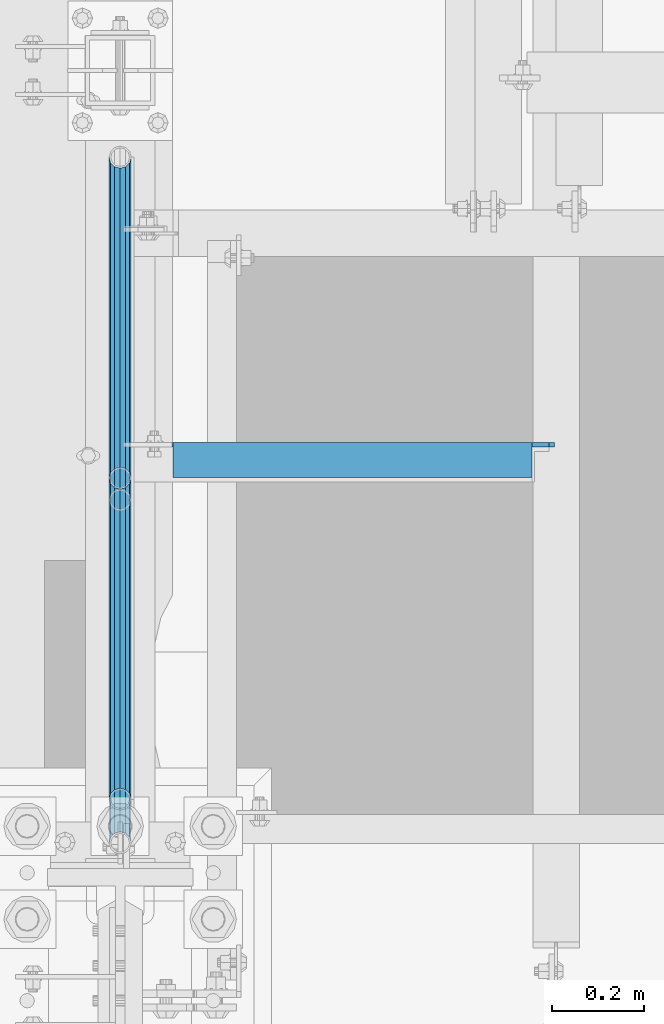
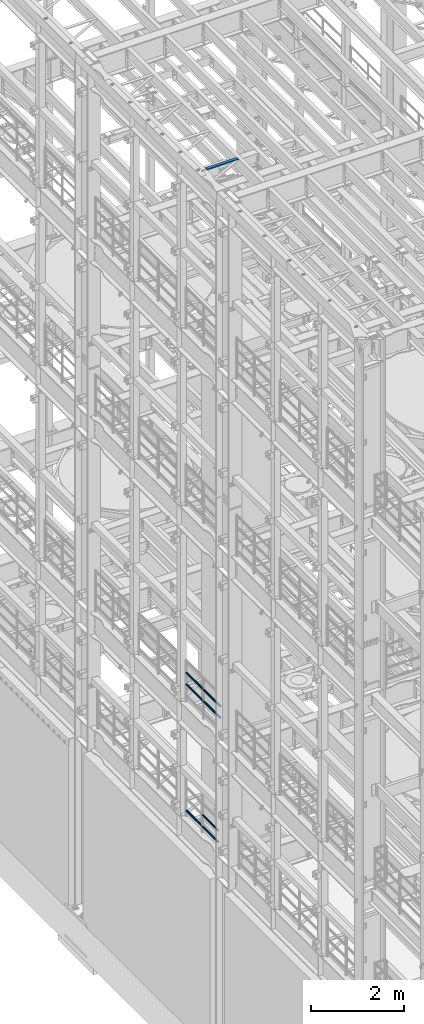
# One storey, part 1246 of 1876: 8 beams, 3 elements without a shape of their own.
"""IFC2X3 building model written with IfcOpenShell, lengths in millimetres."""

from ifc_helpers import new_model, si_unit, frame, origin_with_axes, place, context, subcontext, project, spatial, faceted_brep, material, type_object, element, aggregate, save


model = new_model("IFC2X3")

# Units and contexts
model_context = context("Model", 3, precision=1e-05, world=origin_with_axes())
body_context = subcontext(model_context, "Body", "Model", "MODEL_VIEW")
ifc_project = project(units=[si_unit("LENGTHUNIT", "METRE", prefix="MILLI"), si_unit("AREAUNIT", "SQUARE_METRE"), si_unit("VOLUMEUNIT", "CUBIC_METRE"), si_unit("MASSUNIT", "GRAM", prefix="KILO"), si_unit("TIMEUNIT", "SECOND"), si_unit("PLANEANGLEUNIT", "RADIAN"), si_unit("SOLIDANGLEUNIT", "STERADIAN"), si_unit("THERMODYNAMICTEMPERATUREUNIT", "DEGREE_CELSIUS"), si_unit("LUMINOUSINTENSITYUNIT", "LUMEN")], contexts=[model_context])

# Site, building, storey
site_placement = place(None, origin_with_axes())
site = spatial("IfcSite", under=ifc_project, at=site_placement, CompositionType="ELEMENT")
building_placement = place(site_placement, origin_with_axes())
building = spatial("IfcBuilding", under=site, at=building_placement, Name="Undefined", CompositionType="ELEMENT")
storey_placement = place(building_placement, origin_with_axes())
storey = spatial("IfcBuildingStorey", under=building, at=storey_placement, Name="Undefined", CompositionType="ELEMENT", Elevation=0.0)

# Assembly, beams
assembly_1_placement = place(storey_placement, origin_with_axes())
assembly_1 = element("IfcElementAssembly", 1, at=assembly_1_placement, inside=storey, Name="RAIL", AssemblyPlace="NOTDEFINED", PredefinedType="RIGID_FRAME")
ifc_material_1 = material()
beam_type_1 = type_object("IfcBeamType", Name="PIPE1-1/2SCH40", PredefinedType="NOTDEFINED")
beam_1_placement = place(assembly_1_placement, frame((-1.81898940354586e-12, 1868.805, 8620.125), z_axis=(0.0, 0.0, -1.0), x_axis=(0.0, 1.0, 0.0)))
beam_1 = element("IfcBeam", 2, at=beam_1_placement, type_object=beam_type_1, material=ifc_material_1, Name="RAIL", ObjectType="PIPE1-1/2SCH40", context=body_context, shape_type="Brep", body=[
    faceted_brep([(0.0, 24.1299999999992, 0.0), (12.0650000000064, 20.8971929933177, -12.0649999999987), (12.0650000000064, 20.8971929933177, 12.0649999999987), (12.0650000000064, -20.8971929933177, 12.0649999999987), (12.0650000000064, -20.8971929933177, -12.0649999999987), (0.0, -24.1299999999992, 0.0), (20.8971929933249, -12.0650000000005, 20.8971929933177), (20.8971929933249, -12.0650000000005, 15.8661214311796), (15.2545715621445, -17.7076214311801, 10.2235000000001), (12.5151929933249, -20.4470000000001, 0.0), (15.2545715621445, -17.7076214311801, -10.2235000000001), (20.8971929933249, -12.0650000000005, -15.8661214311796), (20.8971929933249, -12.0650000000005, -20.8971929933177), (24.1300000000063, 0.0, -20.4470000000001), (24.1300000000063, 0.0, -24.130000000001), (21.3906214311868, -10.2235000000001, -17.7076214311819), (21.3906214311868, 10.2235000000001, -17.7076214311819), (20.8971929933249, 12.0650000000005, -15.8661214311796), (20.8971929933249, 12.0650000000005, -20.8971929933177), (15.2545715621445, 17.7076214311801, -10.2235000000001), (12.5151929933249, 20.4470000000001, 0.0), (15.2545715621445, 17.7076214311801, 10.2235000000001), (20.8971929933249, 12.0650000000005, 15.8661214311796), (20.8971929933249, 12.0650000000005, 20.8971929933177), (21.3906214311868, 10.2235000000001, 17.7076214311819), (24.1300000000064, 0.0, 20.4470000000001), (24.1300000000064, 0.0, 24.130000000001), (21.3906214311868, -10.2235000000001, 17.7076214311819), (748.982500000002, 24.1300000000001, 0.0), (736.917500000002, 20.8971929933186, -12.0649999999987), (728.085307006683, 12.0649999999996, -20.8971929933177), (748.982500000002, -24.1300000000001, 0.0), (736.917500000002, -20.8971929933186, -12.0649999999987), (736.917500000002, -20.8971929933186, 12.0649999999987), (728.085307006683, -12.0649999999996, 20.8971929933177), (728.085307006683, -12.0649999999996, -20.8971929933177), (724.852500000002, 0.0, -24.130000000001), (727.591878568821, 10.2235000000001, -17.7076214311819), (724.852500000002, 0.0, -20.4470000000001), (728.085307006683, 12.0649999999996, -15.8661214311796), (728.085307006683, -12.0649999999996, -15.8661214311796), (727.591878568821, -10.2235000000001, -17.7076214311819), (733.727928437864, -17.7076214311801, -10.2235000000001), (736.467307006683, -20.4470000000001, 0.0), (733.727928437864, -17.7076214311801, 10.2235000000001), (728.085307006683, -12.0649999999996, 15.8661214311796), (727.591878568821, -10.2235000000001, 17.7076214311819), (724.852500000002, 0.0, 20.4470000000001), (724.852500000002, 0.0, 24.130000000001), (728.085307006683, 12.0649999999996, 20.8971929933177), (736.917500000002, 20.8971929933186, 12.0649999999987), (728.085307006683, 12.0649999999996, 15.8661214311796), (733.727928437864, 17.7076214311801, 10.2235000000001), (736.467307006683, 20.4470000000001, 0.0), (733.727928437864, 17.7076214311801, -10.2235000000001), (727.591878568821, 10.2235000000001, 17.7076214311819)], [[[0, 1, 2]], [[3, 4, 5]], [[6, 7, 8, 9, 10, 11, 12, 4, 3]], [[13, 14, 12, 11, 15]], [[16, 17, 18, 14, 13]], [[2, 1, 18, 17, 19, 20, 21, 22, 23]], [[23, 22, 24, 25, 26]], [[26, 25, 27, 7, 6]], [[1, 0, 28, 29]], [[18, 1, 29, 30]], [[31, 32, 33]], [[6, 3, 33, 34]], [[3, 5, 31, 33]], [[5, 4, 32, 31]], [[4, 12, 35, 32]], [[12, 14, 36, 35]], [[14, 18, 30, 36]], [[37, 38, 36, 30, 39]], [[40, 35, 36, 38, 41]], [[33, 32, 35, 40, 42, 43, 44, 45, 34]], [[34, 45, 46, 47, 48]], [[26, 6, 34, 48]], [[2, 23, 49, 50]], [[23, 26, 48, 49]], [[0, 2, 50, 28]], [[28, 50, 29]], [[49, 51, 52, 53, 54, 39, 30, 29, 50]], [[48, 47, 55, 51, 49]], [[25, 24, 55, 47]], [[55, 24, 22, 21, 52, 51]], [[21, 20, 53, 52]], [[20, 19, 54, 53]], [[19, 17, 16, 37, 39, 54]], [[16, 13, 38, 37]], [[13, 15, 41, 38]], [[41, 15, 11, 10, 42, 40]], [[10, 9, 43, 42]], [[9, 8, 44, 43]], [[8, 7, 27, 46, 45, 44]], [[27, 25, 47, 46]]]),
])
beam_2_placement = place(assembly_1_placement, frame((-1.81898940354586e-12, 2617.7875, 8620.125), z_axis=(0.0, 0.0, -1.0), x_axis=(0.0, 1.0, 0.0)))
beam_2 = element("IfcBeam", 3, at=beam_2_placement, type_object=beam_type_1, material=ifc_material_1, Name="RAIL", ObjectType="PIPE1-1/2SCH40", context=body_context, shape_type="Brep", body=[
    faceted_brep([(0.0, 24.1299999999992, 0.0), (12.0650000000064, 20.8971929933177, -12.0649999999987), (12.0650000000064, 20.8971929933177, 12.0649999999987), (12.0650000000064, -20.8971929933177, 12.0649999999987), (12.0650000000064, -20.8971929933177, -12.0649999999987), (0.0, -24.1299999999992, 0.0), (20.8971929933249, -12.0650000000005, 20.8971929933177), (20.8971929933249, -12.0650000000005, 15.8661214311796), (15.2545715621445, -17.7076214311801, 10.2235000000001), (12.5151929933249, -20.4470000000001, 0.0), (15.2545715621445, -17.7076214311801, -10.2235000000001), (20.8971929933249, -12.0650000000005, -15.8661214311796), (20.8971929933249, -12.0650000000005, -20.8971929933177), (24.1300000000063, 0.0, -20.4470000000001), (24.1300000000063, 0.0, -24.130000000001), (21.3906214311868, -10.2235000000001, -17.7076214311819), (21.3906214311868, 10.2235000000001, -17.7076214311819), (20.8971929933249, 12.0650000000005, -15.8661214311796), (20.8971929933249, 12.0650000000005, -20.8971929933177), (15.2545715621445, 17.7076214311801, -10.2235000000001), (12.5151929933249, 20.4470000000001, 0.0), (15.2545715621445, 17.7076214311801, 10.2235000000001), (20.8971929933249, 12.0650000000005, 15.8661214311796), (20.8971929933249, 12.0650000000005, 20.8971929933177), (21.3906214311868, 10.2235000000001, 17.7076214311819), (24.1300000000064, 0.0, 20.4470000000001), (24.1300000000064, 0.0, 24.130000000001), (21.3906214311868, -10.2235000000001, 17.7076214311819), (748.982500000002, 24.1300000000001, 0.0), (736.917500000002, 20.8971929933186, -12.0649999999987), (728.085307006683, 12.0649999999996, -20.8971929933177), (748.982500000002, -24.1300000000001, 0.0), (736.917500000002, -20.8971929933186, -12.0649999999987), (736.917500000002, -20.8971929933186, 12.0649999999987), (728.085307006683, -12.0649999999996, 20.8971929933177), (728.085307006683, -12.0649999999996, -20.8971929933177), (724.852500000002, 0.0, -24.130000000001), (727.591878568821, 10.2235000000001, -17.7076214311819), (724.852500000002, 0.0, -20.4470000000001), (728.085307006683, 12.0649999999996, -15.8661214311796), (728.085307006683, -12.0649999999996, -15.8661214311796), (727.591878568821, -10.2235000000001, -17.7076214311819), (733.727928437864, -17.7076214311801, -10.2235000000001), (736.467307006683, -20.4470000000001, 0.0), (733.727928437864, -17.7076214311801, 10.2235000000001), (728.085307006683, -12.0649999999996, 15.8661214311796), (727.591878568821, -10.2235000000001, 17.7076214311819), (724.852500000002, 0.0, 20.4470000000001), (724.852500000002, 0.0, 24.130000000001), (728.085307006683, 12.0649999999996, 20.8971929933177), (736.917500000002, 20.8971929933186, 12.0649999999987), (728.085307006683, 12.0649999999996, 15.8661214311796), (733.727928437864, 17.7076214311801, 10.2235000000001), (736.467307006683, 20.4470000000001, 0.0), (733.727928437864, 17.7076214311801, -10.2235000000001), (727.591878568821, 10.2235000000001, 17.7076214311819)], [[[0, 1, 2]], [[3, 4, 5]], [[6, 7, 8, 9, 10, 11, 12, 4, 3]], [[13, 14, 12, 11, 15]], [[16, 17, 18, 14, 13]], [[2, 1, 18, 17, 19, 20, 21, 22, 23]], [[23, 22, 24, 25, 26]], [[26, 25, 27, 7, 6]], [[1, 0, 28, 29]], [[18, 1, 29, 30]], [[31, 32, 33]], [[6, 3, 33, 34]], [[3, 5, 31, 33]], [[5, 4, 32, 31]], [[4, 12, 35, 32]], [[12, 14, 36, 35]], [[14, 18, 30, 36]], [[37, 38, 36, 30, 39]], [[40, 35, 36, 38, 41]], [[33, 32, 35, 40, 42, 43, 44, 45, 34]], [[34, 45, 46, 47, 48]], [[26, 6, 34, 48]], [[2, 23, 49, 50]], [[23, 26, 48, 49]], [[0, 2, 50, 28]], [[28, 50, 29]], [[49, 51, 52, 53, 54, 39, 30, 29, 50]], [[48, 47, 55, 51, 49]], [[25, 24, 55, 47]], [[55, 24, 22, 21, 52, 51]], [[21, 20, 53, 52]], [[20, 19, 54, 53]], [[19, 17, 16, 37, 39, 54]], [[16, 13, 38, 37]], [[13, 15, 41, 38]], [[41, 15, 11, 10, 42, 40]], [[10, 9, 43, 42]], [[9, 8, 44, 43]], [[8, 7, 27, 46, 45, 44]], [[27, 25, 47, 46]]]),
])
beam_3_placement = place(assembly_1_placement, frame((-1.81898940354586e-12, 1868.805, 8924.925), z_axis=(0.0, 0.0, -1.0), x_axis=(0.0, 1.0, 0.0)))
beam_3 = element("IfcBeam", 4, at=beam_3_placement, type_object=beam_type_1, material=ifc_material_1, Name="RAIL", ObjectType="PIPE1-1/2SCH40", context=body_context, shape_type="Brep", body=[
    faceted_brep([(0.0, 24.1299999999992, 0.0), (12.0650000000064, 20.8971929933177, -12.0649999999987), (12.0650000000064, 20.8971929933177, 12.0649999999987), (12.0650000000064, -20.8971929933177, 12.0649999999987), (12.0650000000064, -20.8971929933177, -12.0649999999987), (0.0, -24.1299999999992, 0.0), (20.8971929933249, -12.0650000000005, 20.8971929933177), (20.8971929933249, -12.0650000000005, 15.8661214311796), (15.2545715621445, -17.7076214311801, 10.2235000000001), (12.5151929933249, -20.4470000000001, 0.0), (15.2545715621445, -17.7076214311801, -10.2235000000001), (20.8971929933249, -12.0650000000005, -15.8661214311796), (20.8971929933249, -12.0650000000005, -20.8971929933177), (24.1300000000063, 0.0, -20.4470000000001), (24.1300000000063, 0.0, -24.130000000001), (21.3906214311868, -10.2235000000001, -17.7076214311819), (21.3906214311868, 10.2235000000001, -17.7076214311819), (20.8971929933249, 12.0650000000005, -15.8661214311796), (20.8971929933249, 12.0650000000005, -20.8971929933177), (15.2545715621445, 17.7076214311801, -10.2235000000001), (12.5151929933249, 20.4470000000001, 0.0), (15.2545715621445, 17.7076214311801, 10.2235000000001), (20.8971929933249, 12.0650000000005, 15.8661214311796), (20.8971929933249, 12.0650000000005, 20.8971929933177), (21.3906214311868, 10.2235000000001, 17.7076214311819), (24.1300000000064, 0.0, 20.4470000000001), (24.1300000000064, 0.0, 24.130000000001), (21.3906214311868, -10.2235000000001, 17.7076214311819), (748.982500000002, 24.1300000000001, 0.0), (736.917500000002, 20.8971929933186, -12.0649999999987), (728.085307006683, 12.0649999999996, -20.8971929933177), (748.982500000002, -24.1300000000001, 0.0), (736.917500000002, -20.8971929933186, -12.0649999999987), (736.917500000002, -20.8971929933186, 12.0649999999987), (728.085307006683, -12.0649999999996, 20.8971929933177), (728.085307006683, -12.0649999999996, -20.8971929933177), (724.852500000002, 0.0, -24.130000000001), (727.591878568821, 10.2235000000001, -17.7076214311819), (724.852500000002, 0.0, -20.4470000000001), (728.085307006683, 12.0649999999996, -15.8661214311796), (728.085307006683, -12.0649999999996, -15.8661214311796), (727.591878568821, -10.2235000000001, -17.7076214311819), (733.727928437864, -17.7076214311801, -10.2235000000001), (736.467307006683, -20.4470000000001, 0.0), (733.727928437864, -17.7076214311801, 10.2235000000001), (728.085307006683, -12.0649999999996, 15.8661214311796), (727.591878568821, -10.2235000000001, 17.7076214311819), (724.852500000002, 0.0, 20.4470000000001), (724.852500000002, 0.0, 24.130000000001), (728.085307006683, 12.0649999999996, 20.8971929933177), (736.917500000002, 20.8971929933186, 12.0649999999987), (728.085307006683, 12.0649999999996, 15.8661214311796), (733.727928437864, 17.7076214311801, 10.2235000000001), (736.467307006683, 20.4470000000001, 0.0), (733.727928437864, 17.7076214311801, -10.2235000000001), (727.591878568821, 10.2235000000001, 17.7076214311819)], [[[0, 1, 2]], [[3, 4, 5]], [[6, 7, 8, 9, 10, 11, 12, 4, 3]], [[13, 14, 12, 11, 15]], [[16, 17, 18, 14, 13]], [[2, 1, 18, 17, 19, 20, 21, 22, 23]], [[23, 22, 24, 25, 26]], [[26, 25, 27, 7, 6]], [[1, 0, 28, 29]], [[18, 1, 29, 30]], [[31, 32, 33]], [[6, 3, 33, 34]], [[3, 5, 31, 33]], [[5, 4, 32, 31]], [[4, 12, 35, 32]], [[12, 14, 36, 35]], [[14, 18, 30, 36]], [[37, 38, 36, 30, 39]], [[40, 35, 36, 38, 41]], [[33, 32, 35, 40, 42, 43, 44, 45, 34]], [[34, 45, 46, 47, 48]], [[26, 6, 34, 48]], [[2, 23, 49, 50]], [[23, 26, 48, 49]], [[0, 2, 50, 28]], [[28, 50, 29]], [[49, 51, 52, 53, 54, 39, 30, 29, 50]], [[48, 47, 55, 51, 49]], [[25, 24, 55, 47]], [[55, 24, 22, 21, 52, 51]], [[21, 20, 53, 52]], [[20, 19, 54, 53]], [[19, 17, 16, 37, 39, 54]], [[16, 13, 38, 37]], [[13, 15, 41, 38]], [[41, 15, 11, 10, 42, 40]], [[10, 9, 43, 42]], [[9, 8, 44, 43]], [[8, 7, 27, 46, 45, 44]], [[27, 25, 47, 46]]]),
])
beam_4_placement = place(assembly_1_placement, frame((-1.81898940354586e-12, 2617.7875, 8924.925), z_axis=(0.0, 0.0, -1.0), x_axis=(0.0, 1.0, 0.0)))
beam_4 = element("IfcBeam", 5, at=beam_4_placement, type_object=beam_type_1, material=ifc_material_1, Name="RAIL", ObjectType="PIPE1-1/2SCH40", context=body_context, shape_type="Brep", body=[
    faceted_brep([(0.0, 24.1299999999992, 0.0), (12.0650000000064, 20.8971929933177, -12.0649999999987), (12.0650000000064, 20.8971929933177, 12.0649999999987), (12.0650000000064, -20.8971929933177, 12.0649999999987), (12.0650000000064, -20.8971929933177, -12.0649999999987), (0.0, -24.1299999999992, 0.0), (20.8971929933249, -12.0650000000005, 20.8971929933177), (20.8971929933249, -12.0650000000005, 15.8661214311796), (15.2545715621445, -17.7076214311801, 10.2235000000001), (12.5151929933249, -20.4470000000001, 0.0), (15.2545715621445, -17.7076214311801, -10.2235000000001), (20.8971929933249, -12.0650000000005, -15.8661214311796), (20.8971929933249, -12.0650000000005, -20.8971929933177), (24.1300000000063, 0.0, -20.4470000000001), (24.1300000000063, 0.0, -24.130000000001), (21.3906214311868, -10.2235000000001, -17.7076214311819), (21.3906214311868, 10.2235000000001, -17.7076214311819), (20.8971929933249, 12.0650000000005, -15.8661214311796), (20.8971929933249, 12.0650000000005, -20.8971929933177), (15.2545715621445, 17.7076214311801, -10.2235000000001), (12.5151929933249, 20.4470000000001, 0.0), (15.2545715621445, 17.7076214311801, 10.2235000000001), (20.8971929933249, 12.0650000000005, 15.8661214311796), (20.8971929933249, 12.0650000000005, 20.8971929933177), (21.3906214311868, 10.2235000000001, 17.7076214311819), (24.1300000000064, 0.0, 20.4470000000001), (24.1300000000064, 0.0, 24.130000000001), (21.3906214311868, -10.2235000000001, 17.7076214311819), (748.982500000002, 24.1300000000001, 0.0), (736.917500000002, 20.8971929933186, -12.0649999999987), (728.085307006683, 12.0649999999996, -20.8971929933177), (748.982500000002, -24.1300000000001, 0.0), (736.917500000002, -20.8971929933186, -12.0649999999987), (736.917500000002, -20.8971929933186, 12.0649999999987), (728.085307006683, -12.0649999999996, 20.8971929933177), (728.085307006683, -12.0649999999996, -20.8971929933177), (724.852500000002, 0.0, -24.130000000001), (727.591878568821, 10.2235000000001, -17.7076214311819), (724.852500000002, 0.0, -20.4470000000001), (728.085307006683, 12.0649999999996, -15.8661214311796), (728.085307006683, -12.0649999999996, -15.8661214311796), (727.591878568821, -10.2235000000001, -17.7076214311819), (733.727928437864, -17.7076214311801, -10.2235000000001), (736.467307006683, -20.4470000000001, 0.0), (733.727928437864, -17.7076214311801, 10.2235000000001), (728.085307006683, -12.0649999999996, 15.8661214311796), (727.591878568821, -10.2235000000001, 17.7076214311819), (724.852500000002, 0.0, 20.4470000000001), (724.852500000002, 0.0, 24.130000000001), (728.085307006683, 12.0649999999996, 20.8971929933177), (736.917500000002, 20.8971929933186, 12.0649999999987), (728.085307006683, 12.0649999999996, 15.8661214311796), (733.727928437864, 17.7076214311801, 10.2235000000001), (736.467307006683, 20.4470000000001, 0.0), (733.727928437864, 17.7076214311801, -10.2235000000001), (727.591878568821, 10.2235000000001, 17.7076214311819)], [[[0, 1, 2]], [[3, 4, 5]], [[6, 7, 8, 9, 10, 11, 12, 4, 3]], [[13, 14, 12, 11, 15]], [[16, 17, 18, 14, 13]], [[2, 1, 18, 17, 19, 20, 21, 22, 23]], [[23, 22, 24, 25, 26]], [[26, 25, 27, 7, 6]], [[1, 0, 28, 29]], [[18, 1, 29, 30]], [[31, 32, 33]], [[6, 3, 33, 34]], [[3, 5, 31, 33]], [[5, 4, 32, 31]], [[4, 12, 35, 32]], [[12, 14, 36, 35]], [[14, 18, 30, 36]], [[37, 38, 36, 30, 39]], [[40, 35, 36, 38, 41]], [[33, 32, 35, 40, 42, 43, 44, 45, 34]], [[34, 45, 46, 47, 48]], [[26, 6, 34, 48]], [[2, 23, 49, 50]], [[23, 26, 48, 49]], [[0, 2, 50, 28]], [[28, 50, 29]], [[49, 51, 52, 53, 54, 39, 30, 29, 50]], [[48, 47, 55, 51, 49]], [[25, 24, 55, 47]], [[55, 24, 22, 21, 52, 51]], [[21, 20, 53, 52]], [[20, 19, 54, 53]], [[19, 17, 16, 37, 39, 54]], [[16, 13, 38, 37]], [[13, 15, 41, 38]], [[41, 15, 11, 10, 42, 40]], [[10, 9, 43, 42]], [[9, 8, 44, 43]], [[8, 7, 27, 46, 45, 44]], [[27, 25, 47, 46]]]),
])
aggregate(assembly_1, [beam_1, beam_2, beam_3, beam_4])

assembly_2_placement = place(storey_placement, origin_with_axes())
assembly_2 = element("IfcElementAssembly", 6, at=assembly_2_placement, inside=storey, Name="RAIL", AssemblyPlace="NOTDEFINED", PredefinedType="RIGID_FRAME")
beam_5_placement = place(assembly_2_placement, frame((-1.81898940354586e-12, 2665.4125, 5292.725), z_axis=(0.0, 0.0, 1.0), x_axis=(0.0, -1.0, 0.0)))
beam_5 = element("IfcBeam", 7, at=beam_5_placement, type_object=beam_type_1, material=ifc_material_1, Name="RAIL", ObjectType="PIPE1-1/2SCH40", context=body_context, shape_type="Brep", body=[
    faceted_brep([(680.460307006681, -12.0649999999996, 20.8971929933186), (680.460307006681, -12.0649999999914, 15.8661214311887), (679.966878568822, -10.2235000000001, 17.7076214311801), (677.2275, 0.0, 20.4470000000001), (677.2275, 0.0, 24.1300000000001), (679.966878568817, 10.2235000000001, 17.7076214311801), (680.460307006681, 12.0650000000078, 15.8661214311724), (680.460307006681, 12.0649999999996, 20.8971929933186), (701.3575, 24.1300000000001, 0.0), (689.2925, 20.8971929933186, 12.0649999999996), (689.2925, 20.8971929933186, -12.0649999999996), (686.102928437854, 17.7076214311801, 10.2235000000001), (688.842307006673, 20.4470000000001, 0.0), (686.102928437854, 17.7076214311801, -10.2235000000001), (680.460307006681, 12.0650000000078, -15.8661214311724), (680.460307006681, 12.0649999999996, -20.8971929933186), (679.966878568817, 10.2235000000001, -17.7076214311801), (677.2275, 0.0, -20.4470000000001), (677.2275, 0.0, -24.1300000000001), (680.460307006681, -12.0649999999914, -15.8661214311887), (680.460307006681, -12.0649999999996, -20.8971929933186), (679.966878568822, -10.2235000000001, -17.7076214311801), (701.3575, -24.1299999999919, 0.0), (689.2925, -20.8971929933186, -12.0649999999996), (689.2925, -20.8971929933186, 12.0649999999996), (686.10292843787, -17.7076214311801, -10.2235000000001), (688.842307006689, -20.4470000000001, 0.0), (686.10292843787, -17.7076214311801, 10.2235000000001), (12.0650000000064, -20.8971929933177, -12.0649999999987), (20.8971929933249, -12.0650000000005, -20.8971929933177), (0.0, 24.1299999999992, 0.0), (12.0650000000064, 20.8971929933177, -12.0649999999987), (12.0650000000064, 20.8971929933177, 12.0649999999987), (20.8971929933249, 12.0650000000005, 20.8971929933177), (24.1300000000064, 0.0, 24.130000000001), (20.8971929933249, 12.0650000000005, -20.8971929933177), (24.1300000000063, 0.0, -24.130000000001), (24.1300000000063, 0.0, -20.4470000000001), (20.8971929933249, -12.0650000000005, -15.8661214311796), (21.3906214311868, -10.2235000000001, -17.7076214311819), (21.3906214311868, 10.2235000000001, -17.7076214311819), (20.8971929933249, 12.0650000000005, -15.8661214311796), (15.2545715621445, 17.7076214311801, -10.2235000000001), (12.5151929933249, 20.4470000000001, 0.0), (15.2545715621445, 17.7076214311801, 10.2235000000001), (20.8971929933249, 12.0650000000005, 15.8661214311796), (21.3906214311868, 10.2235000000001, 17.7076214311819), (24.1300000000064, 0.0, 20.4470000000001), (21.3906214311868, -10.2235000000001, 17.7076214311819), (20.8971929933249, -12.0650000000005, 15.8661214311796), (20.8971929933249, -12.0650000000005, 20.8971929933177), (12.0650000000064, -20.8971929933177, 12.0649999999987), (0.0, -24.1299999999992, 0.0), (15.2545715621445, -17.7076214311801, 10.2235000000001), (12.5151929933249, -20.4470000000001, 0.0), (15.2545715621445, -17.7076214311801, -10.2235000000001)], [[[0, 1, 2, 3, 4]], [[4, 3, 5, 6, 7]], [[8, 9, 10]], [[7, 6, 11, 12, 13, 14, 15, 10, 9]], [[16, 17, 18, 15, 14]], [[19, 20, 18, 17, 21]], [[22, 23, 24]], [[24, 23, 20, 19, 25, 26, 27, 1, 0]], [[28, 29, 20, 23]], [[30, 31, 32]], [[33, 34, 4, 7]], [[32, 33, 7, 9]], [[30, 32, 9, 8]], [[31, 30, 8, 10]], [[35, 31, 10, 15]], [[36, 35, 15, 18]], [[29, 36, 18, 20]], [[37, 36, 29, 38, 39]], [[40, 41, 35, 36, 37]], [[32, 31, 35, 41, 42, 43, 44, 45, 33]], [[33, 45, 46, 47, 34]], [[34, 47, 48, 49, 50]], [[34, 50, 0, 4]], [[50, 51, 24, 0]], [[51, 52, 22, 24]], [[52, 28, 23, 22]], [[51, 28, 52]], [[50, 49, 53, 54, 55, 38, 29, 28, 51]], [[55, 54, 26, 25]], [[21, 39, 38, 55, 25, 19]], [[37, 39, 21, 17]], [[40, 37, 17, 16]], [[42, 41, 40, 16, 14, 13]], [[43, 42, 13, 12]], [[44, 43, 12, 11]], [[5, 46, 45, 44, 11, 6]], [[47, 46, 5, 3]], [[48, 47, 3, 2]], [[53, 49, 48, 2, 1, 27]], [[54, 53, 27, 26]]]),
])
beam_6_placement = place(assembly_2_placement, frame((-1.02100330182984e-11, 3366.77, 5292.725), z_axis=(0.0, 0.0, 1.0), x_axis=(0.0, -1.0, 0.0)))
beam_6 = element("IfcBeam", 8, at=beam_6_placement, type_object=beam_type_1, material=ifc_material_1, Name="RAIL", ObjectType="PIPE1-1/2SCH40", context=body_context, shape_type="Brep", body=[
    faceted_brep([(680.460307006681, -12.0649999999996, 20.8971929933186), (680.460307006681, -12.0649999999914, 15.8661214311887), (679.966878568822, -10.2235000000001, 17.7076214311801), (677.2275, 0.0, 20.4470000000001), (677.2275, 0.0, 24.1300000000001), (679.966878568817, 10.2235000000001, 17.7076214311801), (680.460307006681, 12.0650000000078, 15.8661214311724), (680.460307006681, 12.0649999999996, 20.8971929933186), (701.3575, 24.1300000000001, 0.0), (689.2925, 20.8971929933186, 12.0649999999996), (689.2925, 20.8971929933186, -12.0649999999996), (686.102928437854, 17.7076214311801, 10.2235000000001), (688.842307006673, 20.4470000000001, 0.0), (686.102928437854, 17.7076214311801, -10.2235000000001), (680.460307006681, 12.0650000000078, -15.8661214311724), (680.460307006681, 12.0649999999996, -20.8971929933186), (679.966878568817, 10.2235000000001, -17.7076214311801), (677.2275, 0.0, -20.4470000000001), (677.2275, 0.0, -24.1300000000001), (680.460307006681, -12.0649999999914, -15.8661214311887), (680.460307006681, -12.0649999999996, -20.8971929933186), (679.966878568822, -10.2235000000001, -17.7076214311801), (701.3575, -24.1299999999919, 0.0), (689.2925, -20.8971929933186, -12.0649999999996), (689.2925, -20.8971929933186, 12.0649999999996), (686.10292843787, -17.7076214311801, -10.2235000000001), (688.842307006689, -20.4470000000001, 0.0), (686.10292843787, -17.7076214311801, 10.2235000000001), (12.0650000000064, -20.8971929933177, -12.0649999999987), (20.8971929933249, -12.0650000000005, -20.8971929933177), (0.0, 24.1299999999992, 0.0), (12.0650000000064, 20.8971929933177, -12.0649999999987), (12.0650000000064, 20.8971929933177, 12.0649999999987), (20.8971929933249, 12.0650000000005, 20.8971929933177), (24.1300000000064, 0.0, 24.130000000001), (20.8971929933249, 12.0650000000005, -20.8971929933177), (24.1300000000063, 0.0, -24.130000000001), (24.1300000000063, 0.0, -20.4470000000001), (20.8971929933249, -12.0650000000005, -15.8661214311796), (21.3906214311868, -10.2235000000001, -17.7076214311819), (21.3906214311868, 10.2235000000001, -17.7076214311819), (20.8971929933249, 12.0650000000005, -15.8661214311796), (15.2545715621445, 17.7076214311801, -10.2235000000001), (12.5151929933249, 20.4470000000001, 0.0), (15.2545715621445, 17.7076214311801, 10.2235000000001), (20.8971929933249, 12.0650000000005, 15.8661214311796), (21.3906214311868, 10.2235000000001, 17.7076214311819), (24.1300000000064, 0.0, 20.4470000000001), (21.3906214311868, -10.2235000000001, 17.7076214311819), (20.8971929933249, -12.0650000000005, 15.8661214311796), (20.8971929933249, -12.0650000000005, 20.8971929933177), (12.0650000000064, -20.8971929933177, 12.0649999999987), (0.0, -24.1299999999992, 0.0), (15.2545715621445, -17.7076214311801, 10.2235000000001), (12.5151929933249, -20.4470000000001, 0.0), (15.2545715621445, -17.7076214311801, -10.2235000000001)], [[[0, 1, 2, 3, 4]], [[4, 3, 5, 6, 7]], [[8, 9, 10]], [[7, 6, 11, 12, 13, 14, 15, 10, 9]], [[16, 17, 18, 15, 14]], [[19, 20, 18, 17, 21]], [[22, 23, 24]], [[24, 23, 20, 19, 25, 26, 27, 1, 0]], [[28, 29, 20, 23]], [[30, 31, 32]], [[33, 34, 4, 7]], [[32, 33, 7, 9]], [[30, 32, 9, 8]], [[31, 30, 8, 10]], [[35, 31, 10, 15]], [[36, 35, 15, 18]], [[29, 36, 18, 20]], [[37, 36, 29, 38, 39]], [[40, 41, 35, 36, 37]], [[32, 31, 35, 41, 42, 43, 44, 45, 33]], [[33, 45, 46, 47, 34]], [[34, 47, 48, 49, 50]], [[34, 50, 0, 4]], [[50, 51, 24, 0]], [[51, 52, 22, 24]], [[52, 28, 23, 22]], [[51, 28, 52]], [[50, 49, 53, 54, 55, 38, 29, 28, 51]], [[55, 54, 26, 25]], [[21, 39, 38, 55, 25, 19]], [[37, 39, 21, 17]], [[40, 37, 17, 16]], [[42, 41, 40, 16, 14, 13]], [[43, 42, 13, 12]], [[44, 43, 12, 11]], [[5, 46, 45, 44, 11, 6]], [[47, 46, 5, 3]], [[48, 47, 3, 2]], [[53, 49, 48, 2, 1, 27]], [[54, 53, 27, 26]]]),
])
beam_7_placement = place(assembly_2_placement, frame((-1.81898940354586e-12, 1964.055, 5597.525), z_axis=(0.0, 0.0, -1.0), x_axis=(0.0, 1.0, 0.0)))
beam_7 = element("IfcBeam", 9, at=beam_7_placement, type_object=beam_type_1, material=ifc_material_1, Name="RAIL", ObjectType="PIPE1-1/2SCH40", context=body_context, shape_type="Brep", body=[
    faceted_brep([(0.0, 24.1299999999992, 0.0), (12.0650000000064, 20.8971929933177, -12.0649999999987), (12.0650000000064, 20.8971929933177, 12.0649999999987), (12.0650000000064, -20.8971929933177, 12.0649999999987), (12.0650000000064, -20.8971929933177, -12.0649999999987), (0.0, -24.1299999999992, 0.0), (20.8971929933249, -12.0650000000005, 20.8971929933177), (20.8971929933249, -12.0650000000005, 15.8661214311796), (15.2545715621445, -17.7076214311801, 10.2235000000001), (12.5151929933249, -20.4470000000001, 0.0), (15.2545715621445, -17.7076214311801, -10.2235000000001), (20.8971929933249, -12.0650000000005, -15.8661214311796), (20.8971929933249, -12.0650000000005, -20.8971929933177), (24.1300000000063, 0.0, -20.4470000000001), (24.1300000000063, 0.0, -24.130000000001), (21.3906214311868, -10.2235000000001, -17.7076214311819), (21.3906214311868, 10.2235000000001, -17.7076214311819), (20.8971929933249, 12.0650000000005, -15.8661214311796), (20.8971929933249, 12.0650000000005, -20.8971929933177), (15.2545715621445, 17.7076214311801, -10.2235000000001), (12.5151929933249, 20.4470000000001, 0.0), (15.2545715621445, 17.7076214311801, 10.2235000000001), (20.8971929933249, 12.0650000000005, 15.8661214311796), (20.8971929933249, 12.0650000000005, 20.8971929933177), (21.3906214311868, 10.2235000000001, 17.7076214311819), (24.1300000000064, 0.0, 20.4470000000001), (24.1300000000064, 0.0, 24.130000000001), (21.3906214311868, -10.2235000000001, 17.7076214311819), (701.3575, 24.1300000000001, 0.0), (689.2925, 20.8971929933186, -12.0649999999996), (680.460307006681, 12.0649999999996, -20.8971929933186), (701.3575, -24.1299999999919, 0.0), (689.2925, -20.8971929933186, -12.0649999999996), (689.2925, -20.8971929933186, 12.0649999999996), (680.460307006681, -12.0649999999996, 20.8971929933186), (680.460307006681, -12.0649999999996, -20.8971929933186), (677.2275, 0.0, -24.1300000000001), (679.966878568817, 10.2235000000001, -17.7076214311801), (677.2275, 0.0, -20.4470000000001), (680.460307006681, 12.0650000000078, -15.8661214311724), (680.460307006681, -12.0649999999914, -15.8661214311887), (679.966878568822, -10.2235000000001, -17.7076214311801), (686.10292843787, -17.7076214311801, -10.2235000000001), (688.842307006689, -20.4470000000001, 0.0), (686.10292843787, -17.7076214311801, 10.2235000000001), (680.460307006681, -12.0649999999914, 15.8661214311887), (679.966878568822, -10.2235000000001, 17.7076214311801), (677.2275, 0.0, 20.4470000000001), (677.2275, 0.0, 24.1300000000001), (680.460307006681, 12.0649999999996, 20.8971929933186), (689.2925, 20.8971929933186, 12.0649999999996), (680.460307006681, 12.0650000000078, 15.8661214311724), (686.102928437854, 17.7076214311801, 10.2235000000001), (688.842307006673, 20.4470000000001, 0.0), (686.102928437854, 17.7076214311801, -10.2235000000001), (679.966878568817, 10.2235000000001, 17.7076214311801)], [[[0, 1, 2]], [[3, 4, 5]], [[6, 7, 8, 9, 10, 11, 12, 4, 3]], [[13, 14, 12, 11, 15]], [[16, 17, 18, 14, 13]], [[2, 1, 18, 17, 19, 20, 21, 22, 23]], [[23, 22, 24, 25, 26]], [[26, 25, 27, 7, 6]], [[1, 0, 28, 29]], [[18, 1, 29, 30]], [[31, 32, 33]], [[6, 3, 33, 34]], [[3, 5, 31, 33]], [[5, 4, 32, 31]], [[4, 12, 35, 32]], [[12, 14, 36, 35]], [[14, 18, 30, 36]], [[37, 38, 36, 30, 39]], [[40, 35, 36, 38, 41]], [[33, 32, 35, 40, 42, 43, 44, 45, 34]], [[34, 45, 46, 47, 48]], [[26, 6, 34, 48]], [[2, 23, 49, 50]], [[23, 26, 48, 49]], [[0, 2, 50, 28]], [[28, 50, 29]], [[49, 51, 52, 53, 54, 39, 30, 29, 50]], [[48, 47, 55, 51, 49]], [[25, 24, 55, 47]], [[55, 24, 22, 21, 52, 51]], [[21, 20, 53, 52]], [[20, 19, 54, 53]], [[19, 17, 16, 37, 39, 54]], [[16, 13, 38, 37]], [[13, 15, 41, 38]], [[41, 15, 11, 10, 42, 40]], [[10, 9, 43, 42]], [[9, 8, 44, 43]], [[8, 7, 27, 46, 45, 44]], [[27, 25, 47, 46]]]),
])
aggregate(assembly_2, [beam_5, beam_6, beam_7])

# Assembly, beam
assembly_3_placement = place(storey_placement, origin_with_axes())
assembly_3 = element("IfcElementAssembly", 10, at=assembly_3_placement, inside=storey, Name="ANGLE", AssemblyPlace="NOTDEFINED", PredefinedType="RIGID_FRAME")
ifc_material_2 = material(Name="STEEL/A36")
beam_type_2 = type_object("IfcBeamType", Name="L3X3X3/8", PredefinedType="NOTDEFINED")
beam_8_placement = place(assembly_3_placement, frame((4.51516825708356e-09, 2705.1, 22517.1), z_axis=(0.0, -1.0, 0.0), x_axis=(1.0, 0.0, 0.0)))
beam_8 = element("IfcBeam", 11, at=beam_8_placement, type_object=beam_type_2, material=ifc_material_2, Name="ANGLE", ObjectType="L3X3X3/8", context=body_context, shape_type="Brep", body=[
    faceted_brep([(115.886999817316, 28.5750000000007, 38.0999999999999), (115.886999817316, 38.0999999999985, 38.0999999999999), (115.886998826692, 38.0999999999985, -38.0999999999999), (115.88699882669, 12.699999237062, -38.0999999999999), (115.886998950515, 12.699999237062, -28.5749999999998), (115.88699895052, 28.5750000000007, -28.5749999999998), (38.8937432114558, 12.699999237062, -38.0999999999999), (38.8937433352807, 12.699999237062, -28.5749999999998), (7.14374321145577, -19.050000762938, -38.0999999999999), (7.14374333528067, -19.050000762938, -28.5749999999998), (7.1437499954859, -38.0999999999985, -38.0999999999999), (7.1437499954859, -38.0999999999985, -28.5749999999998), (949.325002419604, 15.8750003814712, -28.5749999999998), (936.625002610339, 28.5750000000007, -28.5749999999998), (900.113000619098, 28.5750000000007, -28.5749999999998), (949.324999995485, -38.0999999999985, -28.5749999999998), (949.325002419604, 3.17500152588036, -28.5749999999998), (900.11300241932, 28.5750000000007, 38.0999999999999), (900.1130024193, 38.0999999999985, 38.0999999999999), (900.113000361957, 38.0999999999985, -38.0999999999999), (900.113000361924, 28.5750001907363, -38.0999999999999), (936.625002353164, 28.5750001907363, -38.0999999999999), (949.325002162429, 15.8750003814712, -38.0999999999999), (949.325002162429, 3.17500152588036, -38.0999999999999), (949.324999995485, -38.0999999999985, -38.0999999999999)], [[[0, 1, 2, 3, 4, 5]], [[4, 3, 6, 7]], [[7, 6, 8, 9]], [[8, 10, 11, 9]], [[12, 13, 14, 5, 4, 7, 9, 11, 15, 16]], [[0, 5, 14, 17]], [[1, 0, 17, 18]], [[2, 1, 18, 19]], [[17, 14, 20, 19, 18]], [[13, 21, 20, 14]], [[12, 22, 21, 13]], [[16, 23, 22, 12]], [[10, 8, 6, 3, 2, 19, 20, 21, 22, 23, 24]], [[11, 10, 24, 15]], [[23, 16, 15, 24]]]),
])
aggregate(assembly_3, [beam_8])

save(model, "model.ifc")
